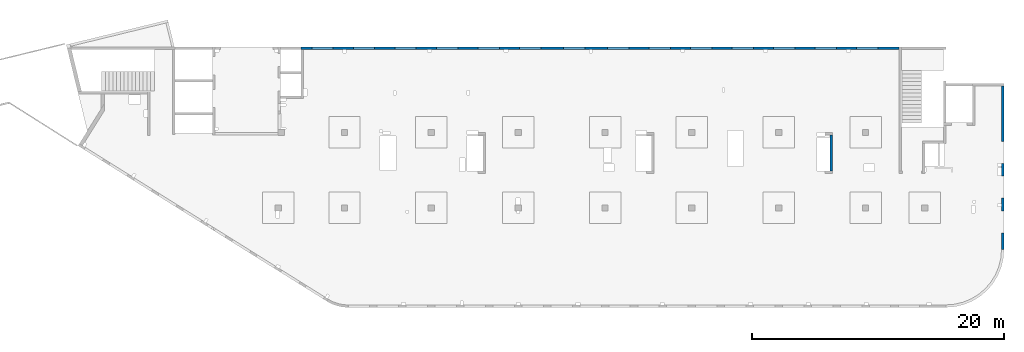
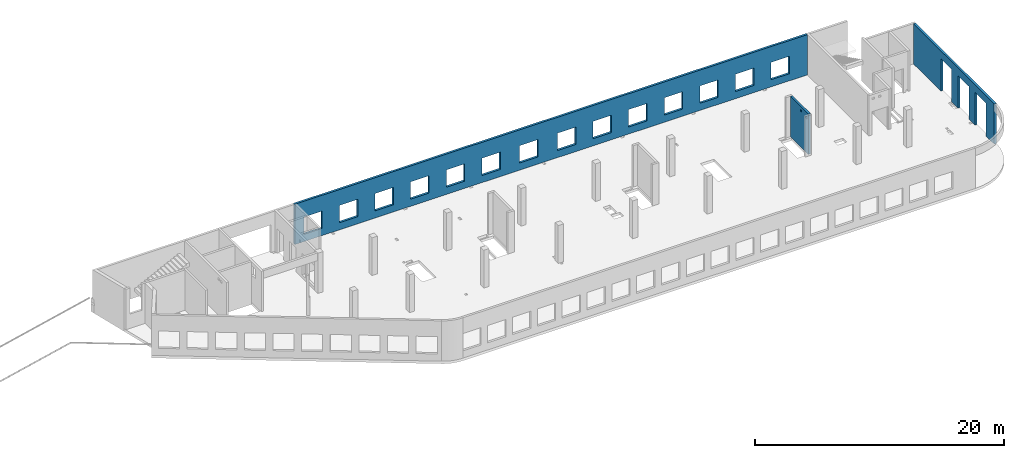
# One storey, part 8 of 8: 3 walls, 19 openings.
"""IFC4 building model written with IfcOpenShell, lengths in millimetres."""

from ifc_helpers import new_model, entity, si_unit, converted_unit, derived_unit, direction, frame, origin, place, context, subcontext, project, spatial, indexed_curve, outline, extrude, polygons, material, type_object, element, save


model = new_model("IFC4")

# Units and contexts
model_context = context("Model", 3, precision=0.01, world=origin(), true_north=direction((6.12303176911189e-17, 1.0)))
plan_context = context("Plan", 3, precision=0.01, world=origin(), true_north=direction((6.12303176911189e-17, 1.0)))
body_context = subcontext(model_context, "Body", "Model", "MODEL_VIEW")
ifc_project = project(units=[si_unit("LENGTHUNIT", "METRE", prefix="MILLI"), si_unit("AREAUNIT", "SQUARE_METRE"), si_unit("VOLUMEUNIT", "CUBIC_METRE"), converted_unit("PLANEANGLEUNIT", "DEGREE", entity("IfcRatioMeasure", 0.0174532925199433), si_unit("PLANEANGLEUNIT", "RADIAN"), dimensions=[0, 0, 0, 0, 0, 0, 0]), si_unit("MASSUNIT", "GRAM", prefix="KILO"), derived_unit("MASSDENSITYUNIT", [(si_unit("MASSUNIT", "GRAM", prefix="KILO"), 1), (si_unit("LENGTHUNIT", "METRE"), -3)]), derived_unit("MOMENTOFINERTIAUNIT", [(si_unit("LENGTHUNIT", "METRE"), 4)]), si_unit("TIMEUNIT", "SECOND"), si_unit("FREQUENCYUNIT", "HERTZ"), si_unit("THERMODYNAMICTEMPERATUREUNIT", "DEGREE_CELSIUS"), derived_unit("THERMALTRANSMITTANCEUNIT", [(si_unit("MASSUNIT", "GRAM", prefix="KILO"), 1), (si_unit("THERMODYNAMICTEMPERATUREUNIT", "KELVIN"), -1), (si_unit("TIMEUNIT", "SECOND"), -3)]), derived_unit("VOLUMETRICFLOWRATEUNIT", [(si_unit("LENGTHUNIT", "METRE"), 3), (si_unit("TIMEUNIT", "SECOND"), -1)]), derived_unit("MASSFLOWRATEUNIT", [(si_unit("MASSUNIT", "GRAM", prefix="KILO"), 1), (si_unit("TIMEUNIT", "SECOND"), -1)]), derived_unit("ROTATIONALFREQUENCYUNIT", [(si_unit("TIMEUNIT", "SECOND"), -1)]), si_unit("ELECTRICCURRENTUNIT", "AMPERE"), si_unit("ELECTRICVOLTAGEUNIT", "VOLT"), si_unit("POWERUNIT", "WATT"), si_unit("FORCEUNIT", "NEWTON", prefix="KILO"), si_unit("ILLUMINANCEUNIT", "LUX"), si_unit("LUMINOUSFLUXUNIT", "LUMEN"), si_unit("LUMINOUSINTENSITYUNIT", "CANDELA"), derived_unit("USERDEFINED", [(si_unit("MASSUNIT", "GRAM", prefix="KILO"), -1), (si_unit("LENGTHUNIT", "METRE"), -2), (si_unit("TIMEUNIT", "SECOND"), 3), (si_unit("LUMINOUSFLUXUNIT", "LUMEN"), 1)]), derived_unit("LINEARVELOCITYUNIT", [(si_unit("LENGTHUNIT", "METRE"), 1), (si_unit("TIMEUNIT", "SECOND"), -1)]), si_unit("PRESSUREUNIT", "PASCAL"), derived_unit("USERDEFINED", [(si_unit("LENGTHUNIT", "METRE"), -2), (si_unit("MASSUNIT", "GRAM", prefix="KILO"), 1), (si_unit("TIMEUNIT", "SECOND"), -2)]), derived_unit("LINEARFORCEUNIT", [(si_unit("MASSUNIT", "GRAM", prefix="KILO"), 1), (si_unit("LENGTHUNIT", "METRE"), 1), (si_unit("TIMEUNIT", "SECOND"), -2), (si_unit("LENGTHUNIT", "METRE"), -1)]), derived_unit("PLANARFORCEUNIT", [(si_unit("MASSUNIT", "GRAM", prefix="KILO"), 1), (si_unit("LENGTHUNIT", "METRE"), 1), (si_unit("TIMEUNIT", "SECOND"), -2), (si_unit("LENGTHUNIT", "METRE"), -2)])], contexts=[model_context, plan_context])

# Site, building, storey
site_placement = place(None, origin())
site = spatial("IfcSite", under=ifc_project, at=site_placement, CompositionType="ELEMENT")
building_placement = place(site_placement, origin())
building = spatial("IfcBuilding", under=site, at=building_placement, CompositionType="ELEMENT")
storey_placement = place(building_placement, frame((0.0, 0.0, 24000.0)))
storey = spatial("IfcBuildingStorey", under=building, at=storey_placement, CompositionType="ELEMENT", Elevation=24000.0)

# Wall, openings
ifc_material = material()
wall_type = type_object("IfcWallType", PredefinedType="STANDARD")
wall_1_placement = place(storey_placement, frame((73469.9994506836, 17369.9992263554, -150.0), z_axis=(0.0, 0.0, 1.0), x_axis=(0.0, -1.0, 0.0)))
wall_1 = element("IfcWall", 1, at=wall_1_placement, inside=storey, type_object=wall_type, material=ifc_material, PredefinedType="NOTDEFINED", context=body_context, shape_type="Tessellation", body=[
    polygons([(12970.0, -99.9999999999918, 0.0), (12970.0, -99.9999999999918, 3200.0), (12970.0, -99.9999999999918, 3950.0), (0.0, -99.9999999999831, 3950.0), (0.0, -99.9999999999831, 0.0), (4394.9999999995, -99.9999999999946, 0.0), (4394.9999999995, -100.000000000003, 3200.0), (6144.9999999995, -100.000000000001, 3200.0), (6144.9999999995, -99.9999999999923, 0.0), (6320.00000000001, -99.999999999992, 0.0), (6485.00000000002, -99.9999999999918, 0.0), (7085.00000000002, -99.999999999991, 0.0), (7144.9999999995, -99.9999999999909, 0.0), (7144.9999999995, -99.9999999999996, 3200.0), (8894.9999999995, -99.9999999999972, 3200.0), (8894.9999999995, -99.9999999999886, 0.0), (9360.00000000001, -99.999999999988, 0.0), (9560.00000000001, -99.9999999999877, 0.0), (9895.00000000005, -99.9999999999959, 0.0), (9895.00000000005, -99.9999999999959, 3200.0), (11645.0, -99.9999999999936, 3200.0), (11645.0, -99.9999999999936, 0.0), (12970.0, 100.000000000006, 3950.0), (12970.0, 100.000000000006, 3200.0), (12970.0, 100.000000000006, 0.0), (11645.0, 100.000000000004, 0.0), (11645.0, 100.000000000316, 3200.0), (9895.00000000005, 100.000000000314, 3200.0), (9895.00000000004, 100.000000000002, 0.0), (8894.9999999995, 100.000000000001, 0.0), (8894.9999999995, 100.00000000033, 3200.0), (7144.9999999995, 100.000000000327, 3200.0), (7144.9999999995, 99.9999999999983, 0.0), (6144.9999999995, 99.9999999999969, 0.0), (6144.9999999995, 100.000000000326, 3200.0), (4394.9999999995, 100.000000000324, 3200.0), (4394.9999999995, 99.9999999999946, 0.0), (0.0, 100.000000000006, 0.0), (0.0, 100.000000000006, 3950.0)], [[[1, 2, 3, 4, 5, 6, 7, 8, 9, 10, 11, 12, 13, 14, 15, 16, 17, 18, 19, 20, 21, 22]], [[23, 24, 25, 26, 27, 28, 29, 30, 31, 32, 33, 34, 35, 36, 37, 38, 39]], [[5, 38, 37, 6]], [[3, 2, 1, 25, 24, 23]], [[4, 3, 23, 39]], [[5, 4, 39, 38]], [[20, 28, 27, 21]], [[28, 20, 19, 29]], [[21, 27, 26, 22]], [[14, 32, 31, 15]], [[32, 14, 13, 33]], [[15, 31, 30, 16]], [[7, 36, 35, 8]], [[36, 7, 6, 37]], [[8, 35, 34, 9]], [[33, 13, 12, 11, 10, 9, 34]], [[29, 19, 18, 17, 16, 30]], [[25, 1, 22, 26]]], closed=True),
])
opening_1_placement = place(wall_1_placement, frame((17369.9992263554, -73469.9994506836, 150.0), z_axis=(0.0, 0.0, 1.0), x_axis=(0.0, 1.0, 0.0)))
element("IfcOpeningElement", 2, at=opening_1_placement, cuts=wall_1, PredefinedType="OPENING", context=body_context, shape_type="SweptSolid", body=[
    extrude(outline(indexed_curve([(-1599.99999999999, -874.999999999999), (1600.0, -874.999999999999), (1600.0, 875.0), (-1599.99999999999, 875.0), (-1599.99999999999, -874.999999999999)], self_intersect=False)), frame((73369.9994506836, 6599.9992263554, 1450.0), z_axis=(1.0, 0.0, 0.0), x_axis=(0.0, 0.0, -1.0)), (0.0, 0.0, 1.0), 200.000000000968),
])
opening_2_placement = place(wall_1_placement, frame((17369.9992263554, -73469.9994506836, 150.0), z_axis=(0.0, 0.0, 1.0), x_axis=(0.0, 1.0, 0.0)))
element("IfcOpeningElement", 3, at=opening_2_placement, cuts=wall_1, PredefinedType="OPENING", context=body_context, shape_type="SweptSolid", body=[
    extrude(outline(indexed_curve([(-1599.99999999999, -874.999999999999), (1600.0, -874.999999999999), (1600.0, 875.0), (-1599.99999999999, 875.0), (-1599.99999999999, -874.999999999999)], self_intersect=False)), frame((73369.9994506836, 9349.99922635595, 1450.0), z_axis=(1.0, 0.0, 0.0), x_axis=(0.0, 0.0, -1.0)), (0.0, 0.0, 1.0), 200.000000000968),
])
opening_3_placement = place(wall_1_placement, frame((17369.9992263554, -73469.9994506836, 150.0), z_axis=(0.0, 0.0, 1.0), x_axis=(0.0, 1.0, 0.0)))
element("IfcOpeningElement", 4, at=opening_3_placement, cuts=wall_1, PredefinedType="OPENING", context=body_context, shape_type="SweptSolid", body=[
    extrude(outline(indexed_curve([(-1599.99999999999, -875.0), (1600.0, -875.0), (1600.0, 875.0), (-1599.99999999999, 875.0), (-1599.99999999999, -875.0)], self_intersect=False)), frame((73369.9994506836, 12099.9992263559, 1450.0), z_axis=(1.0, 0.0, 0.0), x_axis=(0.0, 0.0, -1.0)), (0.0, 0.0, 1.0), 200.000000000968),
])

wall_2_placement = place(storey_placement, frame((65230.0002685547, 20399.9998657227, -150.0), z_axis=(0.0, 0.0, 1.0), x_axis=(-1.0, 0.0, 0.0)))
wall_2 = element("IfcWall", 5, at=wall_2_placement, inside=storey, type_object=wall_type, material=ifc_material, PredefinedType="NOTDEFINED", context=body_context, shape_type="Tessellation", body=[
    polygons([(8.66293703438714e-12, -99.9999999999989, 0.0), (47505.0, -99.9999999999989, 0.0), (47505.0, -99.9999999999989, 3950.0), (8.66293703438714e-12, -99.9999999999989, 3950.0), (28460.0, -100.000000000319, 2400.0), (30160.0, -100.000000000319, 2400.0), (30160.0, -100.000000000319, 700.00000000001), (28460.0, -100.000000000319, 700.00000000001), (1660.00000000009, -100.000000000319, 2400.0), (3360.00000000009, -100.000000000319, 2400.0), (3360.00000000009, -100.000000000319, 700.00000000001), (1660.00000000009, -100.000000000319, 700.00000000001), (4960.00000000009, -100.000000000319, 2400.0), (6660.00000000009, -100.000000000319, 2400.0), (6660.00000000009, -100.000000000319, 700.00000000001), (4960.00000000009, -100.000000000319, 700.00000000001), (8260.00000000008, -100.000000000319, 2400.0), (9960.00000000008, -100.000000000319, 2400.0), (9960.00000000008, -100.000000000319, 700.00000000001), (8260.00000000008, -100.000000000319, 700.00000000001), (11560.0000000001, -100.000000000319, 2400.0), (13260.0000000001, -100.000000000319, 2400.0), (13260.0000000001, -100.000000000319, 700.00000000001), (11560.0000000001, -100.000000000319, 700.00000000001), (14860.0000000001, -100.000000000319, 2400.0), (16560.0000000001, -100.000000000319, 2400.0), (16560.0000000001, -100.000000000319, 700.00000000001), (14860.0000000001, -100.000000000319, 700.00000000001), (18160.0000000001, -100.000000000319, 2400.0), (19860.0000000001, -100.000000000319, 2400.0), (19860.0000000001, -100.000000000319, 700.00000000001), (18160.0000000001, -100.000000000319, 700.00000000001), (21460.0000000001, -100.000000000319, 2400.0), (23160.0000000001, -100.000000000319, 2400.0), (23160.0000000001, -100.000000000319, 700.00000000001), (21460.0000000001, -100.000000000319, 700.00000000001), (24960.0000000001, -100.000000000319, 2400.0), (26660.0000000001, -100.000000000319, 2400.0), (26660.0000000001, -100.000000000319, 700.00000000001), (24960.0000000001, -100.000000000319, 700.00000000001), (31760.0000000001, -100.000000000319, 2400.0), (33460.0000000001, -100.000000000319, 2400.0), (33460.0000000001, -100.000000000319, 700.00000000001), (31760.0000000001, -100.000000000319, 700.00000000001), (35060.0000000001, -100.000000000319, 2400.0), (36760.0000000001, -100.000000000319, 2400.0), (36760.0000000001, -100.000000000319, 700.00000000001), (35060.0000000001, -100.000000000319, 700.00000000001), (38360.0000000001, -100.000000000319, 2400.0), (40060.0000000001, -100.000000000319, 2400.0), (40060.0000000001, -100.000000000319, 700.00000000001), (38360.0000000001, -100.000000000319, 700.00000000001), (41660.0, -100.000000000319, 2400.0), (43360.0, -100.000000000319, 2400.0), (43360.0, -100.000000000319, 700.00000000001), (41660.0, -100.000000000319, 700.00000000001), (44960.0, -100.000000000319, 2400.0), (46660.0, -100.000000000319, 2400.0), (46660.0, -100.000000000319, 700.00000000001), (44960.0, -100.000000000319, 700.00000000001), (8.66293703438714e-12, 99.9999999999989, 0.0), (8.66293703438714e-12, 99.9999999999989, 3950.0), (3860.00000000002, 99.9999999999989, 3950.0), (4160.00000000004, 99.9999999999989, 3950.0), (25630.0, 99.9999999999989, 3950.0), (25930.0, 99.9999999999989, 3950.0), (47305.0, 99.9999999999989, 3950.0), (47505.0, 99.9999999999989, 3950.0), (47505.0, 99.9999999999989, 0.0), (47305.0, 99.9999999999989, 0.0), (30160.0, 99.9999999999989, 2400.0), (28460.0, 99.9999999999989, 2400.0), (28460.0, 99.9999999999989, 700.00000000001), (30160.0, 99.9999999999989, 700.00000000001), (3360.00000000009, 99.9999999999989, 2400.0), (1660.00000000009, 99.9999999999989, 2400.0), (1660.00000000009, 99.9999999999989, 700.00000000001), (3360.00000000009, 99.9999999999989, 700.00000000001), (6660.00000000009, 99.9999999999989, 2400.0), (4960.00000000009, 99.9999999999989, 2400.0), (4960.00000000009, 99.9999999999989, 700.00000000001), (6660.00000000009, 99.9999999999989, 700.00000000001), (9960.00000000008, 99.9999999999989, 2400.0), (8260.00000000008, 99.9999999999989, 2400.0), (8260.00000000008, 99.9999999999989, 700.00000000001), (9960.00000000008, 99.9999999999989, 700.00000000001), (13260.0000000001, 99.9999999999989, 2400.0), (11560.0000000001, 99.9999999999989, 2400.0), (11560.0000000001, 99.9999999999989, 700.00000000001), (13260.0000000001, 99.9999999999989, 700.00000000001), (16560.0000000001, 99.9999999999989, 2400.0), (14860.0000000001, 99.9999999999989, 2400.0), (14860.0000000001, 99.9999999999989, 700.00000000001), (16560.0000000001, 99.9999999999989, 700.00000000001), (19860.0000000001, 99.9999999999989, 2400.0), (18160.0000000001, 99.9999999999989, 2400.0), (18160.0000000001, 99.9999999999989, 700.00000000001), (19860.0000000001, 99.9999999999989, 700.00000000001), (23160.0000000001, 99.9999999999989, 2400.0), (21460.0000000001, 99.9999999999989, 2400.0), (21460.0000000001, 99.9999999999989, 700.00000000001), (23160.0000000001, 99.9999999999989, 700.00000000001), (26660.0000000001, 99.9999999999989, 2400.0), (24960.0000000001, 99.9999999999989, 2400.0), (24960.0000000001, 99.9999999999989, 700.00000000001), (26660.0000000001, 99.9999999999989, 700.00000000001), (33460.0000000001, 99.9999999999989, 2400.0), (31760.0000000001, 99.9999999999989, 2400.0), (31760.0000000001, 99.9999999999989, 700.00000000001), (33460.0000000001, 99.9999999999989, 700.00000000001), (36760.0000000001, 99.9999999999989, 2400.0), (35060.0000000001, 99.9999999999989, 2400.0), (35060.0000000001, 99.9999999999989, 700.00000000001), (36760.0000000001, 99.9999999999989, 700.00000000001), (40060.0000000001, 99.9999999999989, 2400.0), (38360.0000000001, 99.9999999999989, 2400.0), (38360.0000000001, 99.9999999999989, 700.00000000001), (40060.0000000001, 99.9999999999989, 700.00000000001), (43360.0, 99.9999999999989, 2400.0), (41660.0, 99.9999999999989, 2400.0), (41660.0, 99.9999999999989, 700.00000000001), (43360.0, 99.9999999999989, 700.00000000001), (46660.0, 99.9999999999989, 2400.0), (44960.0, 99.9999999999989, 2400.0), (44960.0, 99.9999999999989, 700.00000000001), (46660.0, 99.9999999999989, 700.00000000001)], [[[1, 2, 3, 4], [5, 6, 7, 8], [9, 10, 11, 12], [13, 14, 15, 16], [17, 18, 19, 20], [21, 22, 23, 24], [25, 26, 27, 28], [29, 30, 31, 32], [33, 34, 35, 36], [37, 38, 39, 40], [41, 42, 43, 44], [45, 46, 47, 48], [49, 50, 51, 52], [53, 54, 55, 56], [57, 58, 59, 60]], [[61, 62, 63, 64, 65, 66, 67, 68, 69, 70], [71, 72, 73, 74], [75, 76, 77, 78], [79, 80, 81, 82], [83, 84, 85, 86], [87, 88, 89, 90], [91, 92, 93, 94], [95, 96, 97, 98], [99, 100, 101, 102], [103, 104, 105, 106], [107, 108, 109, 110], [111, 112, 113, 114], [115, 116, 117, 118], [119, 120, 121, 122], [123, 124, 125, 126]], [[2, 1, 61, 70, 69]], [[4, 3, 68, 67, 66, 65, 64, 63, 62]], [[1, 4, 62, 61]], [[3, 2, 69, 68]], [[6, 5, 72, 71]], [[6, 71, 74, 7]], [[7, 74, 73, 8]], [[72, 5, 8, 73]], [[10, 9, 76, 75]], [[10, 75, 78, 11]], [[11, 78, 77, 12]], [[76, 9, 12, 77]], [[14, 13, 80, 79]], [[14, 79, 82, 15]], [[15, 82, 81, 16]], [[80, 13, 16, 81]], [[18, 17, 84, 83]], [[18, 83, 86, 19]], [[19, 86, 85, 20]], [[84, 17, 20, 85]], [[22, 21, 88, 87]], [[22, 87, 90, 23]], [[23, 90, 89, 24]], [[88, 21, 24, 89]], [[26, 25, 92, 91]], [[26, 91, 94, 27]], [[27, 94, 93, 28]], [[92, 25, 28, 93]], [[30, 29, 96, 95]], [[30, 95, 98, 31]], [[31, 98, 97, 32]], [[96, 29, 32, 97]], [[34, 33, 100, 99]], [[34, 99, 102, 35]], [[35, 102, 101, 36]], [[100, 33, 36, 101]], [[38, 37, 104, 103]], [[38, 103, 106, 39]], [[39, 106, 105, 40]], [[104, 37, 40, 105]], [[42, 41, 108, 107]], [[42, 107, 110, 43]], [[43, 110, 109, 44]], [[108, 41, 44, 109]], [[46, 45, 112, 111]], [[46, 111, 114, 47]], [[47, 114, 113, 48]], [[112, 45, 48, 113]], [[50, 49, 116, 115]], [[50, 115, 118, 51]], [[51, 118, 117, 52]], [[116, 49, 52, 117]], [[54, 53, 120, 119]], [[54, 119, 122, 55]], [[55, 122, 121, 56]], [[120, 53, 56, 121]], [[58, 57, 124, 123]], [[58, 123, 126, 59]], [[59, 126, 125, 60]], [[124, 57, 60, 125]]], closed=True),
])
opening_4_placement = place(wall_2_placement, frame((65230.0002685547, 20399.9998657227, 150.0), z_axis=(0.0, 0.0, 1.0), x_axis=(-1.0, 0.0, 0.0)))
element("IfcOpeningElement", 6, at=opening_4_placement, cuts=wall_2, PredefinedType="OPENING", context=body_context, shape_type="SweptSolid", body=[
    extrude(outline(indexed_curve([(-850.000000000002, -849.999999999993), (850.0, -849.999999999993), (850.0, 849.999999999993), (-850.000000000002, 849.999999999993), (-850.000000000002, -849.999999999993)], self_intersect=False)), frame((19420.0002685547, 20499.9998657236, 1400.0), z_axis=(0.0, -1.0, 0.0), x_axis=(-1.0, 0.0, 0.0)), (0.0, 0.0, 1.0), 200.000000000959),
])
opening_5_placement = place(wall_2_placement, frame((65230.0002685547, 20399.9998657227, 150.0), z_axis=(0.0, 0.0, 1.0), x_axis=(-1.0, 0.0, 0.0)))
element("IfcOpeningElement", 7, at=opening_5_placement, cuts=wall_2, PredefinedType="OPENING", context=body_context, shape_type="SweptSolid", body=[
    extrude(outline(indexed_curve([(-850.000000000002, -849.999999999993), (849.999999999997, -849.999999999993), (849.999999999997, 849.999999999993), (-850.000000000002, 849.999999999993), (-850.000000000002, -849.999999999993)], self_intersect=False)), frame((22720.0002685547, 20499.9998657236, 1400.0), z_axis=(0.0, -1.0, 0.0), x_axis=(-1.0, 0.0, 0.0)), (0.0, 0.0, 1.0), 200.000000000959),
])
opening_6_placement = place(wall_2_placement, frame((65230.0002685547, 20399.9998657227, 150.0), z_axis=(0.0, 0.0, 1.0), x_axis=(-1.0, 0.0, 0.0)))
element("IfcOpeningElement", 8, at=opening_6_placement, cuts=wall_2, PredefinedType="OPENING", context=body_context, shape_type="SweptSolid", body=[
    extrude(outline(indexed_curve([(-850.000000000002, -849.999999999993), (849.999999999997, -849.999999999993), (849.999999999997, 849.999999999993), (-850.000000000002, 849.999999999993), (-850.000000000002, -849.999999999993)], self_intersect=False)), frame((26020.0002685547, 20499.9998657236, 1400.0), z_axis=(0.0, -1.0, 0.0), x_axis=(-1.0, 0.0, 0.0)), (0.0, 0.0, 1.0), 200.000000000959),
])
opening_7_placement = place(wall_2_placement, frame((65230.0002685547, 20399.9998657227, 150.0), z_axis=(0.0, 0.0, 1.0), x_axis=(-1.0, 0.0, 0.0)))
element("IfcOpeningElement", 9, at=opening_7_placement, cuts=wall_2, PredefinedType="OPENING", context=body_context, shape_type="SweptSolid", body=[
    extrude(outline(indexed_curve([(-850.000000000002, -849.999999999993), (849.999999999997, -849.999999999993), (849.999999999997, 849.999999999993), (-850.000000000002, 849.999999999993), (-850.000000000002, -849.999999999993)], self_intersect=False)), frame((29320.0002685547, 20499.9998657236, 1400.0), z_axis=(0.0, -1.0, 0.0), x_axis=(-1.0, 0.0, 0.0)), (0.0, 0.0, 1.0), 200.000000000959),
])
opening_8_placement = place(wall_2_placement, frame((65230.0002685547, 20399.9998657227, 150.0), z_axis=(0.0, 0.0, 1.0), x_axis=(-1.0, 0.0, 0.0)))
element("IfcOpeningElement", 10, at=opening_8_placement, cuts=wall_2, PredefinedType="OPENING", context=body_context, shape_type="SweptSolid", body=[
    extrude(outline(indexed_curve([(-849.999999999997, -849.999999999993), (850.000000000002, -849.999999999993), (850.000000000002, 849.999999999993), (-849.999999999997, 849.999999999993), (-849.999999999997, -849.999999999993)], self_intersect=False)), frame((32620.0002685547, 20499.9998657236, 1400.0), z_axis=(0.0, -1.0, 0.0), x_axis=(-1.0, 0.0, 0.0)), (0.0, 0.0, 1.0), 200.000000000959),
])
opening_9_placement = place(wall_2_placement, frame((65230.0002685547, 20399.9998657227, 150.0), z_axis=(0.0, 0.0, 1.0), x_axis=(-1.0, 0.0, 0.0)))
element("IfcOpeningElement", 11, at=opening_9_placement, cuts=wall_2, PredefinedType="OPENING", context=body_context, shape_type="SweptSolid", body=[
    extrude(outline(indexed_curve([(-849.999999999997, -849.999999999993), (850.000000000006, -849.999999999993), (850.000000000006, 849.999999999993), (-849.999999999997, 849.999999999993), (-849.999999999997, -849.999999999993)], self_intersect=False)), frame((39420.0002685547, 20499.9998657236, 1400.0), z_axis=(0.0, -1.0, 0.0), x_axis=(-1.0, 0.0, 0.0)), (0.0, 0.0, 1.0), 200.000000000959),
])
opening_10_placement = place(wall_2_placement, frame((65230.0002685547, 20399.9998657227, 150.0), z_axis=(0.0, 0.0, 1.0), x_axis=(-1.0, 0.0, 0.0)))
element("IfcOpeningElement", 12, at=opening_10_placement, cuts=wall_2, PredefinedType="OPENING", context=body_context, shape_type="SweptSolid", body=[
    extrude(outline(indexed_curve([(-850.000000000006, -849.999999999993), (849.999999999997, -849.999999999993), (849.999999999997, 849.999999999993), (-850.000000000006, 849.999999999993), (-850.000000000006, -849.999999999993)], self_intersect=False)), frame((42920.0002685547, 20499.9998657236, 1400.0), z_axis=(0.0, -1.0, 0.0), x_axis=(-1.0, 0.0, 0.0)), (0.0, 0.0, 1.0), 200.000000000959),
])
opening_11_placement = place(wall_2_placement, frame((65230.0002685547, 20399.9998657227, 150.0), z_axis=(0.0, 0.0, 1.0), x_axis=(-1.0, 0.0, 0.0)))
element("IfcOpeningElement", 13, at=opening_11_placement, cuts=wall_2, PredefinedType="OPENING", context=body_context, shape_type="SweptSolid", body=[
    extrude(outline(indexed_curve([(-849.999999999997, -849.999999999993), (850.000000000006, -849.999999999993), (850.000000000006, 849.999999999993), (-849.999999999997, 849.999999999993), (-849.999999999997, -849.999999999993)], self_intersect=False)), frame((46220.0002685547, 20499.9998657236, 1400.0), z_axis=(0.0, -1.0, 0.0), x_axis=(-1.0, 0.0, 0.0)), (0.0, 0.0, 1.0), 200.000000000959),
])
opening_12_placement = place(wall_2_placement, frame((65230.0002685547, 20399.9998657227, 150.0), z_axis=(0.0, 0.0, 1.0), x_axis=(-1.0, 0.0, 0.0)))
element("IfcOpeningElement", 14, at=opening_12_placement, cuts=wall_2, PredefinedType="OPENING", context=body_context, shape_type="SweptSolid", body=[
    extrude(outline(indexed_curve([(-849.999999999997, -849.999999999993), (850.000000000006, -849.999999999993), (850.000000000006, 849.999999999993), (-849.999999999997, 849.999999999993), (-849.999999999997, -849.999999999993)], self_intersect=False)), frame((49520.0002685547, 20499.9998657236, 1400.0), z_axis=(0.0, -1.0, 0.0), x_axis=(-1.0, 0.0, 0.0)), (0.0, 0.0, 1.0), 200.000000000959),
])
opening_13_placement = place(wall_2_placement, frame((65230.0002685547, 20399.9998657227, 150.0), z_axis=(0.0, 0.0, 1.0), x_axis=(-1.0, 0.0, 0.0)))
element("IfcOpeningElement", 15, at=opening_13_placement, cuts=wall_2, PredefinedType="OPENING", context=body_context, shape_type="SweptSolid", body=[
    extrude(outline(indexed_curve([(-849.999999999997, -849.999999999993), (850.000000000006, -849.999999999993), (850.000000000006, 849.999999999993), (-849.999999999997, 849.999999999993), (-849.999999999997, -849.999999999993)], self_intersect=False)), frame((52820.0002685547, 20499.9998657236, 1400.0), z_axis=(0.0, -1.0, 0.0), x_axis=(-1.0, 0.0, 0.0)), (0.0, 0.0, 1.0), 200.000000000959),
])
opening_14_placement = place(wall_2_placement, frame((65230.0002685547, 20399.9998657227, 150.0), z_axis=(0.0, 0.0, 1.0), x_axis=(-1.0, 0.0, 0.0)))
element("IfcOpeningElement", 16, at=opening_14_placement, cuts=wall_2, PredefinedType="OPENING", context=body_context, shape_type="SweptSolid", body=[
    extrude(outline(indexed_curve([(-849.999999999997, -849.999999999993), (850.000000000006, -849.999999999993), (850.000000000006, 849.999999999993), (-849.999999999997, 849.999999999993), (-849.999999999997, -849.999999999993)], self_intersect=False)), frame((56120.0002685547, 20499.9998657236, 1400.0), z_axis=(0.0, -1.0, 0.0), x_axis=(-1.0, 0.0, 0.0)), (0.0, 0.0, 1.0), 200.000000000959),
])
opening_15_placement = place(wall_2_placement, frame((65230.0002685547, 20399.9998657227, 150.0), z_axis=(0.0, 0.0, 1.0), x_axis=(-1.0, 0.0, 0.0)))
element("IfcOpeningElement", 17, at=opening_15_placement, cuts=wall_2, PredefinedType="OPENING", context=body_context, shape_type="SweptSolid", body=[
    extrude(outline(indexed_curve([(-849.999999999997, -849.999999999993), (850.000000000006, -849.999999999993), (850.000000000006, 849.999999999993), (-849.999999999997, 849.999999999993), (-849.999999999997, -849.999999999993)], self_intersect=False)), frame((59420.0002685547, 20499.9998657236, 1400.0), z_axis=(0.0, -1.0, 0.0), x_axis=(-1.0, 0.0, 0.0)), (0.0, 0.0, 1.0), 200.000000000959),
])
opening_16_placement = place(wall_2_placement, frame((65230.0002685547, 20399.9998657227, 150.0), z_axis=(0.0, 0.0, 1.0), x_axis=(-1.0, 0.0, 0.0)))
element("IfcOpeningElement", 18, at=opening_16_placement, cuts=wall_2, PredefinedType="OPENING", context=body_context, shape_type="SweptSolid", body=[
    extrude(outline(indexed_curve([(-849.999999999997, -849.999999999993), (850.000000000006, -849.999999999993), (850.000000000006, 849.999999999993), (-849.999999999997, 849.999999999993), (-849.999999999997, -849.999999999993)], self_intersect=False)), frame((62720.0002685547, 20499.9998657236, 1400.0), z_axis=(0.0, -1.0, 0.0), x_axis=(-1.0, 0.0, 0.0)), (0.0, 0.0, 1.0), 200.000000000959),
])
opening_17_placement = place(wall_2_placement, frame((65230.0002685547, 20399.9998657227, 150.0), z_axis=(0.0, 0.0, 1.0), x_axis=(-1.0, 0.0, 0.0)))
element("IfcOpeningElement", 19, at=opening_17_placement, cuts=wall_2, PredefinedType="OPENING", context=body_context, shape_type="SweptSolid", body=[
    extrude(outline(indexed_curve([(-849.999999999997, -849.999999999993), (850.000000000002, -849.999999999993), (850.000000000002, 849.999999999993), (-849.999999999997, 849.999999999993), (-849.999999999997, -849.999999999993)], self_intersect=False)), frame((35920.0002685547, 20499.9998657236, 1400.0), z_axis=(0.0, -1.0, 0.0), x_axis=(-1.0, 0.0, 0.0)), (0.0, 0.0, 1.0), 200.000000000959),
])

wall_3_placement = place(storey_placement, frame((59830.0002685547, 13499.9992263555, -150.0), z_axis=(0.0, 0.0, 1.0), x_axis=(0.0, -1.0, 0.0)))
wall_3 = element("IfcWall", 20, at=wall_3_placement, inside=storey, type_object=wall_type, material=ifc_material, PredefinedType="NOTDEFINED", context=body_context, shape_type="Tessellation", body=[
    polygons([(0.0, -99.999999999992, 0.0), (2875.00000000002, -99.9999999999833, 0.0), (2875.00000000002, -99.9999999999833, 3950.0), (205.000000000014, -99.9999999999913, 3950.0), (0.0, -99.999999999992, 3950.0), (2430.00000000002, -100.000000000002, 3500.0), (2630.00000000002, -100.000000000001, 3500.0), (2630.00000000002, -100.000000000001, 3300.00000000001), (2430.00000000002, -100.000000000002, 3300.00000000001), (1585.00000000001, -100.000000000005, 3650.0), (1785.00000000001, -100.000000000004, 3650.0), (1785.00000000001, -100.000000000004, 3450.00000000001), (1585.00000000001, -100.000000000005, 3450.00000000001), (2875.00000000002, 100.000000000006, 0.0), (0.0, 100.000000000006, 0.0), (0.0, 100.000000000006, 3950.0), (2875.00000000002, 100.000000000006, 3950.0), (2630.00000000002, 100.000000000326, 3500.0), (2430.00000000002, 100.000000000325, 3500.0), (2430.00000000002, 100.000000000325, 3300.00000000001), (2630.00000000002, 100.000000000326, 3300.00000000001), (1785.00000000002, 100.000000000323, 3650.0), (1585.00000000001, 100.000000000323, 3650.0), (1585.00000000001, 100.000000000323, 3450.00000000001), (1785.00000000001, 100.000000000323, 3450.00000000001)], [[[1, 2, 3, 4, 5], [6, 7, 8, 9], [10, 11, 12, 13]], [[14, 15, 16, 17], [18, 19, 20, 21], [22, 23, 24, 25]], [[2, 1, 15, 14]], [[1, 5, 16, 15]], [[3, 2, 14, 17]], [[17, 16, 5, 4, 3]], [[19, 18, 7, 6]], [[19, 6, 9, 20]], [[20, 9, 8, 21]], [[7, 18, 21, 8]], [[10, 23, 22, 11]], [[23, 10, 13, 24]], [[24, 13, 12, 25]], [[11, 22, 25, 12]]], closed=True),
])
opening_18_placement = place(wall_3_placement, frame((13499.9992263555, -59830.0002685547, 150.0), z_axis=(0.0, 0.0, 1.0), x_axis=(0.0, 1.0, 0.0)))
element("IfcOpeningElement", 21, at=opening_18_placement, cuts=wall_3, PredefinedType="OPENING", context=body_context, shape_type="SweptSolid", body=[
    extrude(outline(indexed_curve([(-99.9999999999946, -100.000000000001), (99.9999999999903, -100.000000000001), (99.9999999999903, 99.9999999999989), (-99.9999999999946, 99.9999999999989), (-99.9999999999946, -100.000000000001)], self_intersect=False)), frame((59730.0002685547, 11814.9992263555, 3400.0), z_axis=(1.0, 0.0, 0.0), x_axis=(0.0, 0.0, -1.0)), (0.0, 0.0, 1.0), 200.000000000968),
])
opening_19_placement = place(wall_3_placement, frame((13499.9992263555, -59830.0002685547, 150.0), z_axis=(0.0, 0.0, 1.0), x_axis=(0.0, 1.0, 0.0)))
element("IfcOpeningElement", 22, at=opening_19_placement, cuts=wall_3, PredefinedType="OPENING", context=body_context, shape_type="SweptSolid", body=[
    extrude(outline(indexed_curve([(-99.9999999999903, -100.000000000001), (99.9999999999946, -100.000000000001), (99.9999999999946, 99.9999999999989), (-99.9999999999903, 99.9999999999989), (-99.9999999999903, -100.000000000001)], self_intersect=False)), frame((59730.0002685547, 10969.9992263555, 3250.0), z_axis=(1.0, 0.0, 0.0), x_axis=(0.0, 0.0, -1.0)), (0.0, 0.0, 1.0), 200.000000000968),
])

save(model, "model.ifc")
